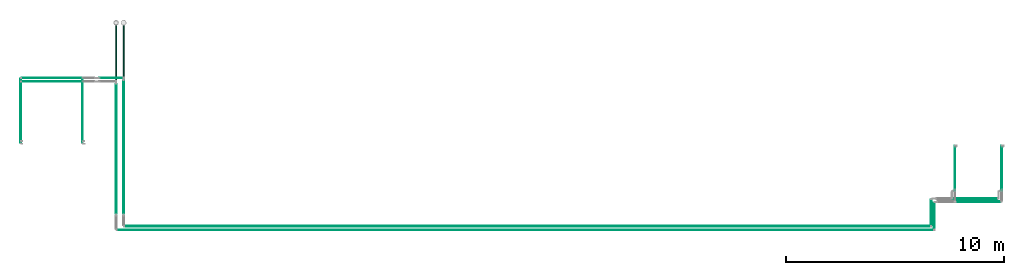
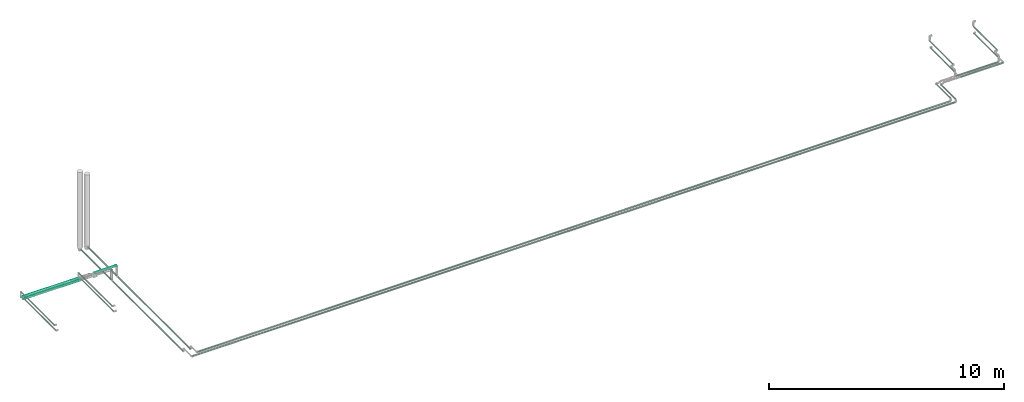
# One storey, part 27 of 39: 21 flow segments.
"""IFC2X3 building model written with IfcOpenShell, lengths in millimetres."""

from ifc_helpers import new_model, entity, si_unit, converted_unit, derived_unit, direction, frame, origin, origin_2d_with_axis, place, context, subcontext, project, spatial, circle, extrude, type_object, element, save


model = new_model("IFC2X3")

# Units and contexts
model_context = context("Model", 3, precision=0.01, world=origin(), true_north=direction((6.12303176911189e-17, 1.0)))
body_context = subcontext(model_context, "Body", "Model", "MODEL_VIEW")
ifc_project = project(units=[si_unit("LENGTHUNIT", "METRE", prefix="MILLI"), si_unit("AREAUNIT", "SQUARE_METRE"), si_unit("VOLUMEUNIT", "CUBIC_METRE"), converted_unit("PLANEANGLEUNIT", "DEGREE", entity("IfcRatioMeasure", 0.0174532925199433), si_unit("PLANEANGLEUNIT", "RADIAN"), dimensions=[0, 0, 0, 0, 0, 0, 0]), si_unit("MASSUNIT", "GRAM", prefix="KILO"), derived_unit("MASSDENSITYUNIT", [(si_unit("MASSUNIT", "GRAM", prefix="KILO"), 1), (si_unit("LENGTHUNIT", "METRE"), -3)]), derived_unit("MOMENTOFINERTIAUNIT", [(si_unit("LENGTHUNIT", "METRE"), 4)]), si_unit("TIMEUNIT", "SECOND"), si_unit("FREQUENCYUNIT", "HERTZ"), si_unit("THERMODYNAMICTEMPERATUREUNIT", "DEGREE_CELSIUS"), derived_unit("THERMALTRANSMITTANCEUNIT", [(si_unit("MASSUNIT", "GRAM", prefix="KILO"), 1), (si_unit("THERMODYNAMICTEMPERATUREUNIT", "KELVIN"), -1), (si_unit("TIMEUNIT", "SECOND"), -3)]), derived_unit("VOLUMETRICFLOWRATEUNIT", [(si_unit("LENGTHUNIT", "METRE"), 3), (si_unit("TIMEUNIT", "SECOND"), -1)]), derived_unit("MASSFLOWRATEUNIT", [(si_unit("MASSUNIT", "GRAM", prefix="KILO"), 1), (si_unit("TIMEUNIT", "SECOND"), -1)]), derived_unit("ROTATIONALFREQUENCYUNIT", [(si_unit("TIMEUNIT", "SECOND"), -1)]), si_unit("ELECTRICCURRENTUNIT", "AMPERE"), si_unit("ELECTRICVOLTAGEUNIT", "VOLT"), si_unit("POWERUNIT", "WATT"), si_unit("FORCEUNIT", "NEWTON", prefix="KILO"), si_unit("ILLUMINANCEUNIT", "LUX"), si_unit("LUMINOUSFLUXUNIT", "LUMEN"), si_unit("LUMINOUSINTENSITYUNIT", "CANDELA"), derived_unit("USERDEFINED", [(si_unit("MASSUNIT", "GRAM", prefix="KILO"), -1), (si_unit("LENGTHUNIT", "METRE"), -2), (si_unit("TIMEUNIT", "SECOND"), 3), (si_unit("LUMINOUSFLUXUNIT", "LUMEN"), 1)]), derived_unit("LINEARVELOCITYUNIT", [(si_unit("LENGTHUNIT", "METRE"), 1), (si_unit("TIMEUNIT", "SECOND"), -1)]), si_unit("PRESSUREUNIT", "PASCAL"), derived_unit("USERDEFINED", [(si_unit("LENGTHUNIT", "METRE"), -2), (si_unit("MASSUNIT", "GRAM", prefix="KILO"), 1), (si_unit("TIMEUNIT", "SECOND"), -2)]), derived_unit("LINEARFORCEUNIT", [(si_unit("MASSUNIT", "GRAM", prefix="KILO"), 1), (si_unit("LENGTHUNIT", "METRE"), 1), (si_unit("TIMEUNIT", "SECOND"), -2), (si_unit("LENGTHUNIT", "METRE"), -1)]), derived_unit("PLANARFORCEUNIT", [(si_unit("MASSUNIT", "GRAM", prefix="KILO"), 1), (si_unit("LENGTHUNIT", "METRE"), 1), (si_unit("TIMEUNIT", "SECOND"), -2), (si_unit("LENGTHUNIT", "METRE"), -2)])], contexts=[model_context])

# Site, building, storey
site_placement = place(None, origin())
site = spatial("IfcSite", under=ifc_project, at=site_placement, CompositionType="ELEMENT")
building_placement = place(site_placement, origin())
building = spatial("IfcBuilding", under=site, at=building_placement, CompositionType="ELEMENT")
storey_placement = place(building_placement, frame((0.0, 0.0, 24000.0)))
storey = spatial("IfcBuildingStorey", under=building, at=storey_placement, Name="07", CompositionType="ELEMENT", Elevation=24000.0)

# Flow segments
pipe_segment_type = type_object("IfcPipeSegmentType", PredefinedType="NOTDEFINED")
flow_segment_1_placement = place(storey_placement, frame((31407.25, 2169.96, 2637.25)))
element("IfcFlowSegment", 1, at=flow_segment_1_placement, inside=storey, type_object=pipe_segment_type, context=body_context, shape_type="SweptSolid", body=[
    extrude(circle(Radius=21.15, at=origin_2d_with_axis()), frame((22.75, 0.0, 22.75), z_axis=(0.0, 1.0, 0.0), x_axis=(-1.0, 0.0, 0.0)), (0.0, 0.0, 1.0), 6119.00000000001),
])
flow_segment_2_placement = place(storey_placement, frame((29517.38, 5434.02, 3281.65)))
element("IfcFlowSegment", 2, at=flow_segment_2_placement, inside=storey, type_object=pipe_segment_type, context=body_context, shape_type="SweptSolid", body=[
    extrude(circle(Radius=16.75, at=origin_2d_with_axis()), frame((18.35, 0.0, 18.35), z_axis=(0.0, 1.0, 0.0), x_axis=(1.0, 0.0, 0.0)), (0.0, 0.0, 1.0), 2779.0585739111),
])
flow_segment_3_placement = place(storey_placement, frame((26681.76, 5554.02, 3481.65)))
element("IfcFlowSegment", 3, at=flow_segment_3_placement, inside=storey, type_object=pipe_segment_type, context=body_context, shape_type="SweptSolid", body=[
    extrude(circle(Radius=16.75, at=origin_2d_with_axis()), frame((18.35, 0.0, 18.35), z_axis=(0.0, 1.0, 0.0), x_axis=(1.0, 0.0, 0.0)), (0.0, 0.0, 1.0), 2817.94105741771),
])
flow_segment_4_placement = place(storey_placement, frame((31054.4, 8308.17, 2634.4)))
element("IfcFlowSegment", 4, at=flow_segment_4_placement, inside=storey, type_object=pipe_segment_type, context=body_context, shape_type="SweptSolid", body=[
    extrude(circle(Radius=24.0, at=origin_2d_with_axis()), frame((25.6, 0.0, 25.6), z_axis=(-8.05859825962109e-08, 1.0, 0.0), x_axis=(1.0, 8.05859825962109e-08, 0.0)), (0.0, 0.0, 1.0), 2559.32784020576),
])
flow_segment_5_placement = place(storey_placement, frame((26738.11, 8232.83, 3181.65)))
element("IfcFlowSegment", 5, at=flow_segment_5_placement, inside=storey, type_object=pipe_segment_type, context=body_context, shape_type="SweptSolid", body=[
    extrude(circle(Radius=16.75, at=origin_2d_with_axis()), frame((0.0, 18.35, 18.35), z_axis=(1.0, 0.0, 0.0), x_axis=(0.0, 1.0, 0.0)), (0.0, 0.0, 1.0), 2759.61647043295),
])
flow_segment_6_placement = place(storey_placement, frame((30314.2, 8391.61, 3181.65)))
element("IfcFlowSegment", 6, at=flow_segment_6_placement, inside=storey, type_object=pipe_segment_type, context=body_context, shape_type="SweptSolid", body=[
    extrude(circle(Radius=16.75, at=origin_2d_with_axis()), frame((0.0, 18.35, 18.35), z_axis=(1.0, 0.0, 0.0), x_axis=(0.0, -1.0, 0.0)), (0.0, 0.0, 1.0), 1077.79898805153),
])
flow_segment_7_placement = place(storey_placement, frame((31477.96, 1578.43, 2803.31)))
element("IfcFlowSegment", 7, at=flow_segment_7_placement, inside=storey, type_object=pipe_segment_type, context=body_context, shape_type="SweptSolid", body=[
    extrude(circle(Radius=21.15, at=origin_2d_with_axis()), frame((0.04, 22.75, 22.75), z_axis=(0.999998000006, 0.0, 0.00199999600001362), x_axis=(0.0, 1.0, 0.0)), (0.0, 0.0, 1.0), 36994.2481264686),
])
flow_segment_8_placement = place(storey_placement, frame((31127.96, 1408.43, 2802.76)))
element("IfcFlowSegment", 8, at=flow_segment_8_placement, inside=storey, type_object=pipe_segment_type, context=body_context, shape_type="SweptSolid", body=[
    extrude(circle(Radius=21.15, at=origin_2d_with_axis()), frame((0.04, 22.75, 22.75), z_axis=(0.999998003749725, 0.0, 0.00199812326063139), x_axis=(0.0, 1.0, 0.0)), (0.0, 0.0, 1.0), 37494.2510963846),
])
flow_segment_9_placement = place(storey_placement, frame((68497.33, 1649.17, 3007.16)))
element("IfcFlowSegment", 9, at=flow_segment_9_placement, inside=storey, type_object=pipe_segment_type, context=body_context, shape_type="SweptSolid", body=[
    extrude(circle(Radius=21.15, at=origin_2d_with_axis()), frame((22.75, 0.0, 22.75), z_axis=(0.0, 0.999999996965674, 7.79015519677106e-05), x_axis=(1.0, 0.0, 0.0)), (0.0, 0.0, 1.0), 1178.18761072129),
])
flow_segment_10_placement = place(storey_placement, frame((68647.33, 1479.17, 3007.21)))
element("IfcFlowSegment", 10, at=flow_segment_10_placement, inside=storey, type_object=pipe_segment_type, context=body_context, shape_type="SweptSolid", body=[
    extrude(circle(Radius=21.15, at=origin_2d_with_axis()), frame((22.75, 0.0, 22.75), z_axis=(0.0, 1.0, 0.0), x_axis=(1.0, 0.0, 0.0)), (0.0, 0.0, 1.0), 1198.17997233305),
])
flow_segment_11_placement = place(storey_placement, frame((31404.4, 8466.96, 2634.4)))
element("IfcFlowSegment", 11, at=flow_segment_11_placement, inside=storey, type_object=pipe_segment_type, context=body_context, shape_type="SweptSolid", body=[
    extrude(circle(Radius=24.0, at=origin_2d_with_axis()), frame((25.6, 0.0, 25.6), z_axis=(0.0, 1.0, 0.0), x_axis=(1.0, 0.0, 0.0)), (0.0, 0.0, 1.0), 2375.54104362635),
])
flow_segment_12_placement = place(storey_placement, frame((31057.25, 2169.96, 2637.25)))
element("IfcFlowSegment", 12, at=flow_segment_12_placement, inside=storey, type_object=pipe_segment_type, context=body_context, shape_type="SweptSolid", body=[
    extrude(circle(Radius=21.15, at=origin_2d_with_axis()), frame((22.75, 0.0, 22.75), z_axis=(0.0, 1.0, 0.0), x_axis=(-1.0, 0.0, 0.0)), (0.0, 0.0, 1.0), 5960.21320346263),
])
flow_segment_13_placement = place(storey_placement, frame((26681.76, 5434.02, 3281.65)))
element("IfcFlowSegment", 13, at=flow_segment_13_placement, inside=storey, type_object=pipe_segment_type, context=body_context, shape_type="SweptSolid", body=[
    extrude(circle(Radius=16.75, at=origin_2d_with_axis()), frame((18.35, 0.0, 18.35), z_axis=(0.0, 1.0, 0.0), x_axis=(1.0, 0.0, 0.0)), (0.0, 0.0, 1.0), 2779.15426085327),
])
flow_segment_14_placement = place(storey_placement, frame((71746.67, 3246.35, 3061.65)))
element("IfcFlowSegment", 14, at=flow_segment_14_placement, inside=storey, type_object=pipe_segment_type, context=body_context, shape_type="SweptSolid", body=[
    extrude(circle(Radius=16.75, at=origin_2d_with_axis()), frame((18.35, 0.0, 18.35), z_axis=(0.0, 1.0, 0.0), x_axis=(-1.0, 0.0, 0.0)), (0.0, 0.0, 1.0), 1983.00000000005),
])
flow_segment_15_placement = place(storey_placement, frame((29517.38, 5554.02, 3481.65)))
element("IfcFlowSegment", 15, at=flow_segment_15_placement, inside=storey, type_object=pipe_segment_type, context=body_context, shape_type="SweptSolid", body=[
    extrude(circle(Radius=16.75, at=origin_2d_with_axis()), frame((18.35, 0.0, 18.35), z_axis=(0.0, 1.0, 0.0), x_axis=(1.0, 0.0, 0.0)), (0.0, 0.0, 1.0), 2817.94105741771),
])
flow_segment_16_placement = place(storey_placement, frame((26738.11, 8391.61, 3181.65)))
element("IfcFlowSegment", 16, at=flow_segment_16_placement, inside=storey, type_object=pipe_segment_type, context=body_context, shape_type="SweptSolid", body=[
    extrude(circle(Radius=16.75, at=origin_2d_with_axis()), frame((0.0, 18.35, 18.35), z_axis=(1.0, 0.0, 0.0), x_axis=(0.0, -1.0, 0.0)), (0.0, 0.0, 1.0), 2759.61647043289),
])
flow_segment_17_placement = place(storey_placement, frame((71746.67, 3334.35, 3381.65)))
element("IfcFlowSegment", 17, at=flow_segment_17_placement, inside=storey, type_object=pipe_segment_type, context=body_context, shape_type="SweptSolid", body=[
    extrude(circle(Radius=16.75, at=origin_2d_with_axis()), frame((18.35, 0.0, 18.35), z_axis=(0.0, 1.0, 0.0), x_axis=(-1.0, 0.0, 0.0)), (0.0, 0.0, 1.0), 1963.00000000006),
])
flow_segment_18_placement = place(storey_placement, frame((69596.67, 3246.35, 3061.65)))
element("IfcFlowSegment", 18, at=flow_segment_18_placement, inside=storey, type_object=pipe_segment_type, context=body_context, shape_type="SweptSolid", body=[
    extrude(circle(Radius=16.75, at=origin_2d_with_axis()), frame((18.35, 0.0, 18.35), z_axis=(0.0, 1.0, 0.0), x_axis=(-1.0, 0.0, 0.0)), (0.0, 0.0, 1.0), 1983.00000000005),
])
flow_segment_19_placement = place(storey_placement, frame((69596.67, 3334.35, 3381.65)))
element("IfcFlowSegment", 19, at=flow_segment_19_placement, inside=storey, type_object=pipe_segment_type, context=body_context, shape_type="SweptSolid", body=[
    extrude(circle(Radius=16.75, at=origin_2d_with_axis()), frame((18.35, 0.0, 18.35), z_axis=(0.0, 1.0, 0.0), x_axis=(-1.0, 0.0, 0.0)), (0.0, 0.0, 1.0), 1963.00000000006),
])
flow_segment_20_placement = place(storey_placement, frame((69513.01, 2852.61, 3057.25)))
element("IfcFlowSegment", 20, at=flow_segment_20_placement, inside=storey, type_object=pipe_segment_type, context=body_context, shape_type="SweptSolid", body=[
    extrude(circle(Radius=21.15, at=origin_2d_with_axis()), frame((0.0, 22.75, 22.75), z_axis=(1.0, 0.0, 0.0), x_axis=(0.0, 1.0, 0.0)), (0.0, 0.0, 1.0), 2054.0),
])
flow_segment_21_placement = place(storey_placement, frame((69663.01, 2702.61, 3057.22)))
element("IfcFlowSegment", 21, at=flow_segment_21_placement, inside=storey, type_object=pipe_segment_type, context=body_context, shape_type="SweptSolid", body=[
    extrude(circle(Radius=21.15, at=origin_2d_with_axis()), frame((0.0, 22.75, 22.75), z_axis=(1.0, 0.0, 1.50942445411724e-05), x_axis=(0.0, 1.0, 0.0)), (0.0, 0.0, 1.0), 2054.00000021723),
])

save(model, "model.ifc")
